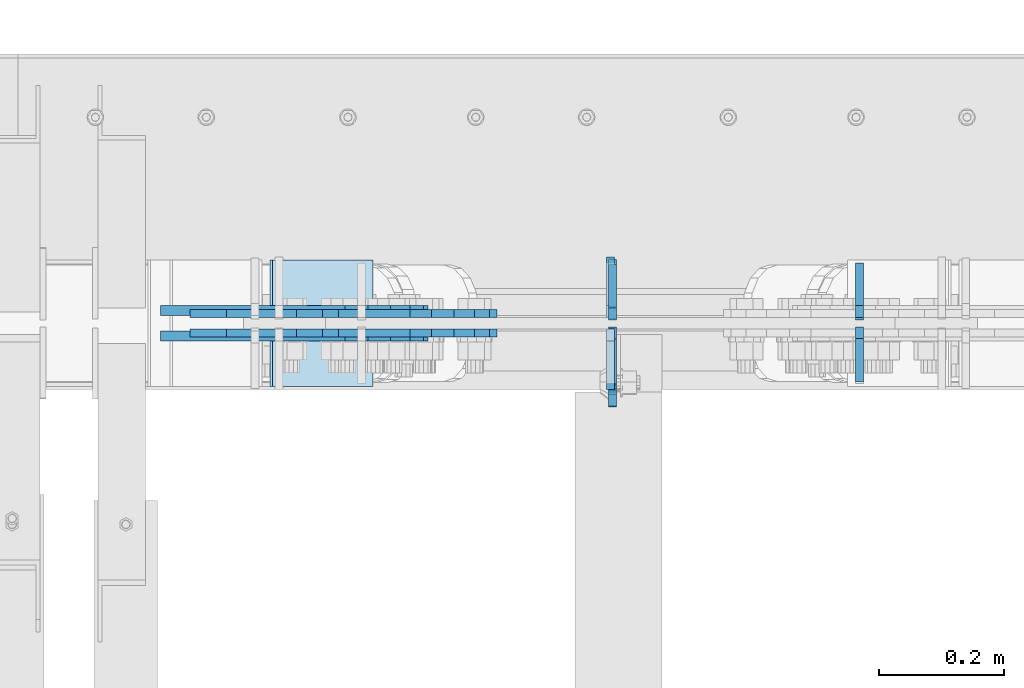
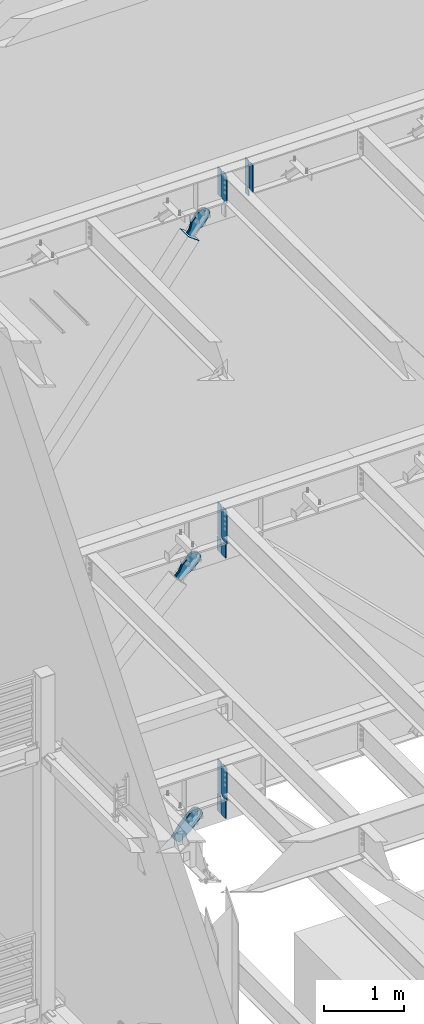
# One storey, part 1069 of 1179: 20 plates, 10 elements without a shape of their own.
"""IFC2X3 building model written with IfcOpenShell, lengths in millimetres."""

from ifc_helpers import new_model, si_unit, frame, origin_with_axes, place, context, subcontext, project, spatial, faceted_brep, material, type_object, element, aggregate, save


model = new_model("IFC2X3")

# Units and contexts
model_context = context("Model", 3, precision=1e-05, world=origin_with_axes())
body_context = subcontext(model_context, "Body", "Model", "MODEL_VIEW")
ifc_project = project(units=[si_unit("LENGTHUNIT", "METRE", prefix="MILLI"), si_unit("AREAUNIT", "SQUARE_METRE"), si_unit("VOLUMEUNIT", "CUBIC_METRE"), si_unit("MASSUNIT", "GRAM", prefix="KILO"), si_unit("TIMEUNIT", "SECOND"), si_unit("PLANEANGLEUNIT", "RADIAN"), si_unit("SOLIDANGLEUNIT", "STERADIAN"), si_unit("THERMODYNAMICTEMPERATUREUNIT", "DEGREE_CELSIUS"), si_unit("LUMINOUSINTENSITYUNIT", "LUMEN")], contexts=[model_context])

# Site, building, storey
site_placement = place(None, origin_with_axes())
site = spatial("IfcSite", under=ifc_project, at=site_placement, CompositionType="ELEMENT")
building_placement = place(site_placement, origin_with_axes())
building = spatial("IfcBuilding", under=site, at=building_placement, Name="Undefined", CompositionType="ELEMENT")
storey_placement = place(building_placement, origin_with_axes())
storey = spatial("IfcBuildingStorey", under=building, at=storey_placement, Name="Undefined", CompositionType="ELEMENT", Elevation=0.0)

# Assembly, plate
assembly_1_placement = place(storey_placement, origin_with_axes())
assembly_1 = element("IfcElementAssembly", 1, at=assembly_1_placement, inside=storey, Name="BEAM", AssemblyPlace="NOTDEFINED", PredefinedType="RIGID_FRAME")
ifc_material_1 = material(Name="STEEL/A572-GR.50")
plate_type_1 = type_object("IfcPlateType", PredefinedType="NOTDEFINED")
plate_1_placement = place(assembly_1_placement, frame((4359.27488286661, 41205.94375, 7489.825), z_axis=(0.0, 0.0, 1.0), x_axis=(0.0, 1.0, 0.0)))
plate_1 = element("IfcPlate", 2, at=plate_1_placement, type_object=plate_type_1, material=ifc_material_1, Name="PLATE", context=body_context, shape_type="Brep", body=[
    faceted_brep([(0.0, -6.35000000000036, 19.0499999999993), (0.0, -6.350000000195, 479.425000761541), (0.0, 6.34999999980209, 479.425000761548), (0.0, 6.35000000000036, 19.0499999999993), (19.0499992370605, -6.35000000019863, 498.474999998592), (19.0499992370605, 6.34999999979118, 498.474999998596), (95.25, -6.349999999793, 498.474999998598), (95.25, 6.35000000020045, 498.474999998592), (95.25, -6.34999999999309, 1.81898940354586e-12), (95.25, 6.34999999999854, -1.81898940354586e-12), (19.0500000000002, -6.35000000000036, 0.0), (19.0500000000002, 6.35000000000036, 0.0)], [[[0, 1, 2, 3]], [[1, 4, 5, 2]], [[4, 6, 7, 5]], [[6, 8, 9, 7]], [[8, 10, 11, 9]], [[3, 11, 10, 0]], [[5, 7, 9, 11, 3, 2]], [[10, 8, 6, 4, 1, 0]]]),
])

assembly_2_placement = place(storey_placement, origin_with_axes())
assembly_2 = element("IfcElementAssembly", 3, at=assembly_2_placement, inside=storey, Name="BEAM", AssemblyPlace="NOTDEFINED", PredefinedType="RIGID_FRAME")
plate_2_placement = place(assembly_2_placement, frame((4359.27477863734, 41205.94375, 3578.225), z_axis=(0.0, 0.0, 1.0), x_axis=(0.0, 1.0, 0.0)))
plate_2 = element("IfcPlate", 4, at=plate_2_placement, type_object=plate_type_1, material=ifc_material_1, Name="PLATE", context=body_context, shape_type="Brep", body=[
    faceted_brep([(0.0, -6.35000000000036, 19.0499999999993), (0.0, -6.350000000195, 479.425000761541), (0.0, 6.34999999980209, 479.425000761548), (0.0, 6.35000000000036, 19.0499999999993), (19.0499992370605, -6.35000000019863, 498.474999998592), (19.0499992370605, 6.34999999979118, 498.474999998596), (95.25, -6.349999999793, 498.474999998598), (95.25, 6.35000000020045, 498.474999998592), (95.25, -6.34999999999309, 1.81898940354586e-12), (95.25, 6.34999999999854, -1.81898940354586e-12), (19.0500000000002, -6.35000000000036, 0.0), (19.0500000000002, 6.35000000000036, 0.0)], [[[0, 1, 2, 3]], [[1, 4, 5, 2]], [[4, 6, 7, 5]], [[6, 8, 9, 7]], [[8, 10, 11, 9]], [[3, 11, 10, 0]], [[5, 7, 9, 11, 3, 2]], [[10, 8, 6, 4, 1, 0]]]),
])

assembly_3_placement = place(storey_placement, origin_with_axes())
assembly_3 = element("IfcElementAssembly", 5, at=assembly_3_placement, inside=storey, Name="Plate", AssemblyPlace="NOTDEFINED", PredefinedType="RIGID_FRAME")
ifc_material_2 = material(Name="STEEL/A36")
plate_type_2 = type_object("IfcPlateType", PredefinedType="NOTDEFINED")
plate_3_placement = place(assembly_3_placement, frame((3974.02897240542, 41097.2, 12217.0925888361), z_axis=(-0.795206441873757, 0.0, 0.606338778903741), x_axis=(0.0, 1.0, 0.0)))
plate_3 = element("IfcPlate", 6, at=plate_3_placement, type_object=plate_type_2, material=ifc_material_2, Name="Plate", context=body_context, shape_type="Brep", body=[
    faceted_brep([(0.0, -3.17500000000109, 0.0), (0.0, -3.17500000000291, 203.200000000368), (0.0, 3.17499999998836, 203.200000000361), (0.0, 3.17500000000109, 7.27595761418343e-12), (203.199999999997, -3.17500000000291, 203.200000000368), (203.199999999997, 3.17499999998836, 203.200000000361), (203.199999999997, -3.17499999999927, 3.63797880709171e-12), (203.199999999997, 3.17499999999382, -3.63797880709171e-12)], [[[0, 1, 2, 3]], [[1, 4, 5, 2]], [[4, 6, 7, 5]], [[6, 0, 3, 7]], [[5, 7, 3, 2]], [[6, 4, 1, 0]]]),
])
aggregate(assembly_3, [plate_3])

assembly_4_placement = place(storey_placement, origin_with_axes())
assembly_4 = element("IfcElementAssembly", 7, at=assembly_4_placement, inside=storey, Name="BEAM", AssemblyPlace="NOTDEFINED", PredefinedType="RIGID_FRAME")
plate_type_3 = type_object("IfcPlateType", PredefinedType="NOTDEFINED")
plate_4_placement = place(assembly_4_placement, frame((4755.23166249237, 41208.325, 12652.3749993443), z_axis=(0.0, 1.0, 0.0), x_axis=(0.0, 0.0, -1.0)))
plate_4 = element("IfcPlate", 8, at=plate_4_placement, type_object=plate_type_3, material=ifc_material_1, Name="PLATE", context=body_context, shape_type="Brep", body=[
    faceted_brep([(0.0, 6.35000000000036, 19.0499999999993), (19.0500000000002, 6.35000000000036, 0.0), (19.0500000000002, -6.35000000000036, 0.0), (0.0, -6.35000000000036, 19.0499999999993), (0.0, -6.35000000000036, 87.3125), (0.0, 6.35000000000036, 87.3125), (92.4827269854632, -6.35000000000036, 87.3125), (92.4827269854632, 6.35000000000036, 87.3125), (92.4827269854632, -6.35000000000036, 0.0), (92.4827269854632, 6.35000000000036, 0.0)], [[[0, 1, 2, 3]], [[4, 5, 0, 3]], [[4, 6, 7, 5]], [[6, 8, 9, 7]], [[9, 8, 2, 1]], [[5, 7, 9, 1, 0]], [[8, 6, 4, 3, 2]]]),
])

# Plate
plate_type_4 = type_object("IfcPlateType", PredefinedType="NOTDEFINED")
plate_5_placement = place(assembly_1_placement, frame((4356.09999912136, 41208.325, 7464.425), z_axis=(0.0, 1.0, 0.0), x_axis=(0.0, 0.0, -1.0)))
plate_5 = element("IfcPlate", 9, at=plate_5_placement, type_object=plate_type_4, material=ifc_material_1, Name="PLATE", context=body_context, shape_type="Brep", body=[
    faceted_brep([(0.0, 6.35000000000036, 19.0499999999993), (19.0500000000002, 6.35000000000036, 0.0), (19.0500000000002, -6.35000000000036, 0.0), (0.0, -6.35000000000036, 19.0499999999993), (0.0, -6.35000000000036, 96.8374999999978), (0.0, 6.35000000000036, 96.8374999999978), (210.586547343888, -6.35000000000036, 96.8375000000015), (210.586547343888, 6.35000000000036, 96.8375000000015), (210.586547343888, -6.35000000000036, 0.0), (210.586547343888, 6.35000000000036, 0.0)], [[[0, 1, 2, 3]], [[4, 5, 0, 3]], [[4, 6, 7, 5]], [[6, 8, 9, 7]], [[9, 8, 2, 1]], [[5, 7, 9, 1, 0]], [[8, 6, 4, 3, 2]]]),
])

plate_6_placement = place(assembly_1_placement, frame((4356.09999912136, 41189.275, 7464.425), z_axis=(0.0, -1.0, 0.0), x_axis=(0.0, 0.0, -1.0)))
plate_6 = element("IfcPlate", 10, at=plate_6_placement, type_object=plate_type_4, material=ifc_material_1, Name="PLATE", context=body_context, shape_type="Brep", body=[
    faceted_brep([(0.0, 6.35000000000036, 19.0499999999993), (19.0500000000002, 6.35000000000036, 0.0), (19.0500000000002, -6.35000000000036, 0.0), (0.0, -6.35000000000036, 19.0499999999993), (0.0, -6.35000000000036, 96.8374999999978), (0.0, 6.35000000000036, 96.8374999999978), (210.586547343888, -6.35000000000036, 96.8375000000015), (210.586547343888, 6.35000000000036, 96.8375000000015), (210.586547343888, -6.35000000000036, 0.0), (210.586547343888, 6.35000000000036, 0.0)], [[[0, 1, 2, 3]], [[4, 5, 0, 3]], [[4, 6, 7, 5]], [[6, 8, 9, 7]], [[9, 8, 2, 1]], [[5, 7, 9, 1, 0]], [[8, 6, 4, 3, 2]]]),
])

plate_type_5 = type_object("IfcPlateType", PredefinedType="NOTDEFINED")
plate_7_placement = place(assembly_4_placement, frame((4755.25703537455, 41104.34375, 12673.0125), z_axis=(0.0, 0.0, 1.0), x_axis=(0.0, 1.0, 0.0)))
plate_7 = element("IfcPlate", 11, at=plate_7_placement, type_object=plate_type_5, material=ifc_material_1, Name="PLATE", context=body_context, shape_type="Brep", body=[
    faceted_brep([(0.0, -6.34999999999854, 0.0), (0.0, -6.34999999999991, 425.450012207031), (0.0, 6.34999999999991, 425.450012207031), (0.0, 6.34999999999854, 0.0), (69.8500022888184, -6.34999999999991, 425.450012207031), (69.8500022888184, 6.34999999999991, 425.450012207031), (88.9000015258789, -6.34999999999991, 406.400012969971), (88.9000015258789, 6.34999999999991, 406.400012969971), (88.9000015258789, -6.34999999999991, 19.0499992370605), (88.9000015258789, 6.34999999999991, 19.0499992370605), (69.849999425729, -6.34999999999854, 0.0), (69.849999425729, 6.34999999999854, 0.0)], [[[0, 1, 2, 3]], [[1, 4, 5, 2]], [[4, 6, 7, 5]], [[6, 8, 9, 7]], [[8, 10, 11, 9]], [[10, 0, 3, 11]], [[5, 7, 9, 11, 3, 2]], [[10, 8, 6, 4, 1, 0]]]),
])

plate_8_placement = place(assembly_4_placement, frame((4755.25703537455, 41204.35625, 12673.0125), z_axis=(0.0, 0.0, 1.0), x_axis=(0.0, 1.0, 0.0)))
plate_8 = element("IfcPlate", 12, at=plate_8_placement, type_object=plate_type_5, material=ifc_material_1, Name="PLATE", context=body_context, shape_type="Brep", body=[
    faceted_brep([(0.0, -6.35000000000036, 19.0499999999993), (0.0, -6.34999999999991, 406.400012969971), (0.0, 6.34999999999991, 406.400012969971), (0.0, 6.35000000000036, 19.0499999999993), (19.0499992370605, -6.34999999999991, 425.450012207031), (19.0499992370605, 6.34999999999991, 425.450012207031), (88.9000015258789, -6.34999999999991, 425.450012207031), (88.9000015258789, 6.34999999999991, 425.450012207031), (88.9000015258789, -6.34999999999991, 0.0), (88.9000015258789, 6.34999999999991, 0.0), (19.0500000000002, -6.35000000000036, 0.0), (19.0500000000002, 6.35000000000036, 0.0)], [[[0, 1, 2, 3]], [[1, 4, 5, 2]], [[4, 6, 7, 5]], [[6, 8, 9, 7]], [[8, 10, 11, 9]], [[3, 11, 10, 0]], [[5, 7, 9, 11, 3, 2]], [[10, 8, 6, 4, 1, 0]]]),
])

plate_9_placement = place(assembly_4_placement, frame((4359.275, 41204.35625, 12673.0125), z_axis=(0.0, 0.0, 1.0), x_axis=(0.0, 1.0, 0.0)))
plate_9 = element("IfcPlate", 13, at=plate_9_placement, type_object=plate_type_5, material=ifc_material_1, Name="PLATE", context=body_context, shape_type="Brep", body=[
    faceted_brep([(0.0, -6.35000000000036, 19.0499999999993), (0.0, -6.34999999999991, 406.400012969971), (0.0, 6.34999999999991, 406.400012969971), (0.0, 6.35000000000036, 19.0499999999993), (19.0499992370605, -6.34999999999991, 425.450012207031), (19.0499992370605, 6.34999999999991, 425.450012207031), (88.9000015258789, -6.34999999999991, 425.450012207031), (88.9000015258789, 6.34999999999991, 425.450012207031), (88.9000015258789, -6.34999999999991, 0.0), (88.9000015258789, 6.34999999999991, 0.0), (19.0500000000002, -6.35000000000036, 0.0), (19.0500000000002, 6.35000000000036, 0.0)], [[[0, 1, 2, 3]], [[1, 4, 5, 2]], [[4, 6, 7, 5]], [[6, 8, 9, 7]], [[8, 10, 11, 9]], [[3, 11, 10, 0]], [[5, 7, 9, 11, 3, 2]], [[10, 8, 6, 4, 1, 0]]]),
])

plate_type_6 = type_object("IfcPlateType", PredefinedType="NOTDEFINED")
plate_10_placement = place(assembly_4_placement, frame((4359.275, 41193.24375, 12673.0125), z_axis=(0.0, 0.0, 1.0), x_axis=(0.0, -1.0, 0.0)))
plate_10 = element("IfcPlate", 14, at=plate_10_placement, type_object=plate_type_6, material=ifc_material_1, Name="PLATE", context=body_context, shape_type="Brep", body=[
    faceted_brep([(91.2812527563583, -6.35000000000036, 425.450000000001), (91.2812527563583, -6.35000000000036, 420.68750041225), (91.2812527563583, 6.35000000000036, 420.68750041225), (91.2812527563583, 6.35000000000036, 425.450000000001), (92.2479826789495, -6.35000000000036, 415.827420894204), (92.2479826789495, 6.35000000000036, 415.827420894204), (95.0009965794234, -6.35000000000036, 411.70724442605), (95.0009965794234, 6.35000000000036, 411.70724442605), (99.121173047577, -6.35000000000036, 408.954230525573), (99.121173047577, 6.35000000000036, 408.954230525573), (103.981252565623, -6.35000000000036, 407.987500602985), (103.981252565623, 6.35000000000036, 407.987500602985), (127.000010385753, -6.35000000000036, 407.987500602985), (127.000004873051, 6.35000000000036, 407.987500602985), (0.0, -6.34999999999991, 406.400012969971), (19.0499992370605, -6.34999999999991, 425.450012207031), (19.0499992370605, 6.34999999999991, 425.450012207031), (0.0, 6.34999999999991, 406.400012969971), (0.0, -6.35000000000036, 19.0499999999993), (0.0, 6.35000000000036, 19.0499999999993), (19.0500000000002, 6.35000000000036, 0.0), (19.0500000000002, -6.35000000000036, 0.0), (127.000004873051, -6.34999999999854, 0.0), (127.000004873051, 6.34999999999854, 0.0)], [[[0, 1, 2, 3]], [[4, 5, 2, 1]], [[6, 7, 5, 4]], [[8, 9, 7, 6]], [[10, 11, 9, 8]], [[12, 13, 11, 10]], [[14, 15, 16, 17]], [[18, 14, 17, 19]], [[19, 20, 21, 18]], [[22, 21, 20, 23]], [[8, 6, 4, 1, 0, 15, 14, 18, 21, 22, 12, 10]], [[16, 15, 0, 3]], [[23, 20, 19, 17, 16, 3, 2, 5, 7, 9, 11, 13]], [[22, 23, 13, 12]]]),
])

aggregate(assembly_4, [plate_7, plate_8, plate_4, plate_9, plate_10])

plate_11_placement = place(assembly_1_placement, frame((4359.27488286661, 41191.65625, 7489.825), z_axis=(0.0, 0.0, 1.0), x_axis=(0.0, -1.0, 0.0)))
plate_11 = element("IfcPlate", 15, at=plate_11_placement, type_object=plate_type_6, material=ifc_material_1, Name="PLATE", context=body_context, shape_type="Brep", body=[
    faceted_brep([(99.21875, -6.35000000020227, 498.474999998592), (99.2187500000146, -6.35000000000036, 492.124999809268), (99.2187500000146, 6.35000000000036, 492.124999809268), (99.21875, 6.34999999978754, 498.474999998596), (100.185479922602, -6.35000000000036, 487.264920291223), (100.185479922602, 6.35000000000036, 487.264920291223), (102.93849382308, -6.35000000000036, 483.144743823069), (102.93849382308, 6.35000000000036, 483.144743823069), (107.058670291233, -6.35000000000036, 480.39172992259), (107.058670291233, 6.35000000000036, 480.39172992259), (111.91874980928, -6.35000000000036, 479.425000000003), (111.91874980928, 6.35000000000036, 479.425000000003), (127.000007629409, -6.35000000000036, 479.425000000003), (127.000004683807, 6.35000000000036, 479.425000000003), (0.0, -6.350000000195, 479.425000761541), (19.0499992370605, -6.35000000019863, 498.474999998592), (19.0499992370605, 6.34999999979118, 498.474999998596), (0.0, 6.34999999980209, 479.425000761548), (0.0, -6.35000000000036, 19.0499999999993), (0.0, 6.35000000000036, 19.0499999999993), (19.0500000000002, 6.35000000000036, 0.0), (19.0500000000002, -6.35000000000036, 0.0), (127.000004873051, -6.34999999999854, 0.0), (127.000004873051, 6.34999999999854, 0.0)], [[[0, 1, 2, 3]], [[4, 5, 2, 1]], [[6, 7, 5, 4]], [[8, 9, 7, 6]], [[10, 11, 9, 8]], [[12, 13, 11, 10]], [[14, 15, 16, 17]], [[18, 14, 17, 19]], [[19, 20, 21, 18]], [[22, 21, 20, 23]], [[8, 6, 4, 1, 0, 15, 14, 18, 21, 22, 12, 10]], [[15, 0, 3, 16]], [[23, 20, 19, 17, 16, 3, 2, 5, 7, 9, 11, 13]], [[22, 23, 13, 12]]]),
])

aggregate(assembly_1, [plate_5, plate_6, plate_1, plate_11])

plate_12_placement = place(assembly_2_placement, frame((4359.27477865803, 41191.6562498413, 3578.225), z_axis=(0.0, 0.0, 1.0), x_axis=(0.0, -1.0, 0.0)))
plate_12 = element("IfcPlate", 16, at=plate_12_placement, type_object=plate_type_6, material=ifc_material_1, Name="PLATE", context=body_context, shape_type="Brep", body=[
    faceted_brep([(100.185729598081, -6.34999999998126, 493.614920291231), (100.185729712379, 6.35000000001855, 493.614920291231), (99.2189997897876, 6.35000000001764, 498.475), (99.2189996754969, -6.34999999998217, 498.475), (102.938743498562, -6.34999999998035, 489.494743823076), (102.93874361286, 6.35000000001946, 489.494743823076), (107.058919966723, -6.34999999998035, 486.741729922599), (107.058920081021, 6.35000000001946, 486.741729922599), (111.918999484777, -6.34999999997945, 485.775000000015), (111.918999599067, 6.35000000002037, 485.775000000015), (127.000007633353, -6.34999999997581, 485.775000000033), (127.000004873036, 6.35000000002401, 485.775000000033), (0.0, -6.350000000195, 479.425000761541), (19.0499992370605, -6.35000000019863, 498.474999998592), (19.0499992370605, 6.34999999979118, 498.474999998596), (0.0, 6.34999999980209, 479.425000761548), (0.0, -6.35000000000036, 19.0499999999993), (0.0, 6.35000000000036, 19.0499999999993), (19.0500000000002, 6.35000000000036, 0.0), (19.0500000000002, -6.35000000000036, 0.0), (127.000004873051, -6.34999999999854, 0.0), (127.000004873051, 6.34999999999854, 0.0)], [[[0, 1, 2, 3]], [[4, 5, 1, 0]], [[6, 7, 5, 4]], [[8, 9, 7, 6]], [[10, 11, 9, 8]], [[12, 13, 14, 15]], [[16, 12, 15, 17]], [[17, 18, 19, 16]], [[20, 19, 18, 21]], [[6, 4, 0, 3, 13, 12, 16, 19, 20, 10, 8]], [[14, 13, 3, 2]], [[21, 18, 17, 15, 14, 2, 1, 5, 7, 9, 11]], [[20, 21, 11, 10]]]),
])

plate_type_7 = type_object("IfcPlateType", PredefinedType="NOTDEFINED")
plate_13_placement = place(assembly_2_placement, frame((4356.09999808618, 41211.5, 3552.825), z_axis=(0.0, 1.0, 0.0), x_axis=(0.0, 0.0, -1.0)))
plate_13 = element("IfcPlate", 17, at=plate_13_placement, type_object=plate_type_7, material=ifc_material_1, Name="PLATE", context=body_context, shape_type="Brep", body=[
    faceted_brep([(0.0, -6.35000000000036, 93.6625000000058), (0.0, 6.35000000000036, 93.6625000000058), (0.0, 6.35000000000036, 19.0499999999993), (0.0, -6.35000000000036, 19.0499999999993), (264.218438426346, -6.35000000000036, 93.6625000000058), (264.218438426346, 6.35000000000036, 93.6625000000058), (264.218438426346, -6.35000000000036, 0.0), (264.218438426346, 6.35000000000036, 0.0), (19.0500000000002, -6.35000000000036, 0.0), (19.0500000000002, 6.35000000000036, 0.0)], [[[0, 1, 2, 3]], [[0, 4, 5, 1]], [[4, 6, 7, 5]], [[6, 8, 9, 7]], [[2, 9, 8, 3]], [[5, 7, 9, 2, 1]], [[8, 6, 4, 0, 3]]]),
])

plate_14_placement = place(assembly_2_placement, frame((4356.09999808618, 41186.1, 3552.825), z_axis=(0.0, -1.0, 0.0), x_axis=(0.0, 0.0, -1.0)))
plate_14 = element("IfcPlate", 18, at=plate_14_placement, type_object=plate_type_7, material=ifc_material_1, Name="PLATE", context=body_context, shape_type="Brep", body=[
    faceted_brep([(0.0, -6.35000000000036, 93.6625000000058), (0.0, 6.35000000000036, 93.6625000000058), (0.0, 6.35000000000036, 19.0499999999993), (0.0, -6.35000000000036, 19.0499999999993), (264.218438426346, -6.35000000000036, 93.6625000000058), (264.218438426346, 6.35000000000036, 93.6625000000058), (264.218438426346, -6.35000000000036, 0.0), (264.218438426346, 6.35000000000036, 0.0), (19.0500000000002, -6.35000000000036, 0.0), (19.0500000000002, 6.35000000000036, 0.0)], [[[0, 1, 2, 3]], [[0, 4, 5, 1]], [[4, 6, 7, 5]], [[6, 8, 9, 7]], [[2, 9, 8, 3]], [[5, 7, 9, 2, 1]], [[8, 6, 4, 0, 3]]]),
])

aggregate(assembly_2, [plate_13, plate_14, plate_2, plate_12])

# Assembly, plate
assembly_5_placement = place(storey_placement, origin_with_axes())
assembly_5 = element("IfcElementAssembly", 19, at=assembly_5_placement, inside=storey, AssemblyPlace="NOTDEFINED", PredefinedType="RIGID_FRAME")
plate_type_8 = type_object("IfcPlateType", PredefinedType="NOTDEFINED")
plate_15_placement = place(assembly_5_placement, frame((3929.93946276912, 41214.675, 12246.717826004), z_axis=(-0.795206441873757, 0.0, 0.606338778903741), x_axis=(0.606338778903741, 0.0, 0.795206441873757)))
plate_15 = element("IfcPlate", 20, at=plate_15_placement, type_object=plate_type_8, material=ifc_material_2, context=body_context, shape_type="Brep", body=[
    faceted_brep([(0.0, -6.34999999999854, 0.0), (4.938556230627e-10, -6.34999999999854, 97.1536165479993), (4.938556230627e-10, 6.34999999999854, 97.1536165479993), (0.0, 6.34999999999854, 0.0), (68.5800000003655, -6.34999999999854, 97.153616547841), (68.5800000003655, 6.34999999999854, 97.153616547841), (170.180000000595, -6.34999999999854, 142.239308273867), (170.180000000595, 6.34999999999854, 142.239308273867), (313.949242323917, -6.34999999999854, 142.239308273847), (313.949242323917, 6.34999999999854, 142.239308273847), (349.792328723946, -6.34999999999854, 135.109675103793), (349.792328723946, 6.34999999999854, 135.109675103793), (380.178630137938, -6.34999999999854, 114.80619761351), (380.178630137938, 6.34999999999854, 114.80619761351), (400.482107628101, -6.34999999999854, 84.4198961994261), (400.482107628101, 6.34999999999854, 84.4198961994261), (407.611740798023, -6.34999999999854, 48.5768067476838), (407.611740798023, 6.34999999999854, 48.5768067476838), (400.482107627932, -6.34999999999854, 12.7337203478164), (400.482107627932, 6.34999999999854, 12.7337203478164), (380.178630137746, -6.34999999999854, -17.6525810660296), (380.178630137746, 6.34999999999854, -17.6525810660296), (349.79232872385, -6.34999999999854, -37.9560585561248), (349.79232872385, 6.34999999999854, -37.9560585561248), (313.949240797645, -6.34999999999854, -45.085691726099), (313.949240797645, 6.34999999999854, -45.085691726099), (170.17999999998, -6.34999999999854, -45.0856917260735), (170.17999999998, 6.34999999999854, -45.0856917260735), (68.5800000000518, -6.34999999999854, -9.09494701772928e-12), (68.5800000000518, 6.34999999999854, -9.09494701772928e-12)], [[[0, 1, 2, 3]], [[1, 4, 5, 2]], [[4, 6, 7, 5]], [[6, 8, 9, 7]], [[8, 10, 11, 9]], [[10, 12, 13, 11]], [[12, 14, 15, 13]], [[14, 16, 17, 15]], [[16, 18, 19, 17]], [[18, 20, 21, 19]], [[20, 22, 23, 21]], [[22, 24, 25, 23]], [[24, 26, 27, 25]], [[26, 28, 29, 27]], [[28, 0, 3, 29]], [[5, 7, 9, 11, 13, 15, 17, 19, 21, 23, 25, 27, 29, 3, 2]], [[28, 26, 24, 22, 20, 18, 16, 14, 12, 10, 8, 6, 4, 1, 0]]]),
])
aggregate(assembly_5, [plate_15])

assembly_6_placement = place(storey_placement, origin_with_axes())
assembly_6 = element("IfcElementAssembly", 21, at=assembly_6_placement, inside=storey, AssemblyPlace="NOTDEFINED", PredefinedType="RIGID_FRAME")
plate_16_placement = place(assembly_6_placement, frame((3929.93946276912, 41182.925, 12246.717826004), z_axis=(-0.795206441873757, 0.0, 0.606338778903741), x_axis=(0.606338778903741, 0.0, 0.795206441873757)))
plate_16 = element("IfcPlate", 22, at=plate_16_placement, type_object=plate_type_8, material=ifc_material_2, context=body_context, shape_type="Brep", body=[
    faceted_brep([(0.0, -6.34999999999854, 0.0), (4.938556230627e-10, -6.34999999999854, 97.1536165479993), (4.938556230627e-10, 6.34999999999854, 97.1536165479993), (0.0, 6.34999999999854, 0.0), (68.5800000003655, -6.34999999999854, 97.153616547841), (68.5800000003655, 6.34999999999854, 97.153616547841), (170.180000000595, -6.34999999999854, 142.239308273867), (170.180000000595, 6.34999999999854, 142.239308273867), (313.949242323917, -6.34999999999854, 142.239308273847), (313.949242323917, 6.34999999999854, 142.239308273847), (349.792328723946, -6.34999999999854, 135.109675103793), (349.792328723946, 6.34999999999854, 135.109675103793), (380.178630137938, -6.34999999999854, 114.80619761351), (380.178630137938, 6.34999999999854, 114.80619761351), (400.482107628101, -6.34999999999854, 84.4198961994261), (400.482107628101, 6.34999999999854, 84.4198961994261), (407.611740798023, -6.34999999999854, 48.5768067476838), (407.611740798023, 6.34999999999854, 48.5768067476838), (400.482107627932, -6.34999999999854, 12.7337203478164), (400.482107627932, 6.34999999999854, 12.7337203478164), (380.178630137746, -6.34999999999854, -17.6525810660296), (380.178630137746, 6.34999999999854, -17.6525810660296), (349.79232872385, -6.34999999999854, -37.9560585561248), (349.79232872385, 6.34999999999854, -37.9560585561248), (313.949240797645, -6.34999999999854, -45.085691726099), (313.949240797645, 6.34999999999854, -45.085691726099), (170.17999999998, -6.34999999999854, -45.0856917260735), (170.17999999998, 6.34999999999854, -45.0856917260735), (68.5800000000518, -6.34999999999854, -9.09494701772928e-12), (68.5800000000518, 6.34999999999854, -9.09494701772928e-12)], [[[0, 1, 2, 3]], [[1, 4, 5, 2]], [[4, 6, 7, 5]], [[6, 8, 9, 7]], [[8, 10, 11, 9]], [[10, 12, 13, 11]], [[12, 14, 15, 13]], [[14, 16, 17, 15]], [[16, 18, 19, 17]], [[18, 20, 21, 19]], [[20, 22, 23, 21]], [[22, 24, 25, 23]], [[24, 26, 27, 25]], [[26, 28, 29, 27]], [[28, 0, 3, 29]], [[5, 7, 9, 11, 13, 15, 17, 19, 21, 23, 25, 27, 29, 3, 2]], [[28, 26, 24, 22, 20, 18, 16, 14, 12, 10, 8, 6, 4, 1, 0]]]),
])
aggregate(assembly_6, [plate_16])

assembly_7_placement = place(storey_placement, origin_with_axes())
assembly_7 = element("IfcElementAssembly", 23, at=assembly_7_placement, inside=storey, AssemblyPlace="NOTDEFINED", PredefinedType="RIGID_FRAME")
plate_17_placement = place(assembly_7_placement, frame((3761.14514710402, 41214.675, 7066.8345998703), z_axis=(-0.705959813968941, 0.0, 0.708251890968841), x_axis=(0.70825189096884, 0.0, 0.705959813968941)))
plate_17 = element("IfcPlate", 24, at=plate_17_placement, type_object=plate_type_8, material=ifc_material_2, context=body_context, shape_type="Brep", body=[
    faceted_brep([(0.0, -6.34999999999854, 0.0), (-4.35647962149233e-10, -6.34999999999854, 112.184930806416), (-4.35647962149233e-10, 6.34999999999854, 112.184930806416), (0.0, 6.34999999999854, 0.0), (82.5499999996491, -6.34999999999854, 112.184930806461), (82.5499999996491, 6.34999999999854, 112.184930806461), (184.149999999618, -6.34999999999854, 149.75496540347), (184.149999999618, 6.34999999999854, 149.75496540347), (327.919242323534, -6.34999999999854, 149.754965403559), (327.919242323534, 6.34999999999854, 149.754965403559), (363.762328723451, -6.34999999999854, 142.625332233587), (363.762328723451, 6.34999999999854, 142.625332233587), (394.148630137406, -6.34999999999854, 122.321854743475), (394.148630137406, 6.34999999999854, 122.321854743475), (414.452107627645, -6.34999999999854, 91.9355533295929), (414.452107627645, 6.34999999999854, 91.9355533295929), (421.581740797776, -6.34999999999854, 56.0924638777396), (421.581740797776, 6.34999999999854, 56.0924638777396), (414.452107627878, -6.34999999999854, 20.2493774776722), (414.452107627878, 6.34999999999854, 20.2493774776722), (394.14863013775, -6.34999999999854, -10.1369239363994), (394.14863013775, 6.34999999999854, -10.1369239363994), (363.762328723789, -6.34999999999854, -30.4404014266784), (363.762328723789, 6.34999999999854, -30.4404014266784), (327.919240798041, -6.34999999999854, -37.570034596738), (327.919240798041, 6.34999999999854, -37.570034596738), (184.150000000338, -6.34999999999854, -37.5700345968289), (184.150000000338, 6.34999999999854, -37.5700345968289), (82.550000000203, -6.34999999999854, 1.2732925824821e-10), (82.550000000203, 6.34999999999854, 1.2732925824821e-10)], [[[0, 1, 2, 3]], [[1, 4, 5, 2]], [[4, 6, 7, 5]], [[6, 8, 9, 7]], [[8, 10, 11, 9]], [[10, 12, 13, 11]], [[12, 14, 15, 13]], [[14, 16, 17, 15]], [[16, 18, 19, 17]], [[18, 20, 21, 19]], [[20, 22, 23, 21]], [[22, 24, 25, 23]], [[24, 26, 27, 25]], [[26, 28, 29, 27]], [[28, 0, 3, 29]], [[5, 7, 9, 11, 13, 15, 17, 19, 21, 23, 25, 27, 29, 3, 2]], [[28, 26, 24, 22, 20, 18, 16, 14, 12, 10, 8, 6, 4, 1, 0]]]),
])
aggregate(assembly_7, [plate_17])

assembly_8_placement = place(storey_placement, origin_with_axes())
assembly_8 = element("IfcElementAssembly", 25, at=assembly_8_placement, inside=storey, AssemblyPlace="NOTDEFINED", PredefinedType="RIGID_FRAME")
plate_18_placement = place(assembly_8_placement, frame((3761.14514710402, 41182.925, 7066.8345998703), z_axis=(-0.705959813968941, 0.0, 0.708251890968841), x_axis=(0.70825189096884, 0.0, 0.705959813968941)))
plate_18 = element("IfcPlate", 26, at=plate_18_placement, type_object=plate_type_8, material=ifc_material_2, context=body_context, shape_type="Brep", body=[
    faceted_brep([(0.0, -6.34999999999854, 0.0), (-4.35647962149233e-10, -6.34999999999854, 112.184930806416), (-4.35647962149233e-10, 6.34999999999854, 112.184930806416), (0.0, 6.34999999999854, 0.0), (82.5499999996491, -6.34999999999854, 112.184930806461), (82.5499999996491, 6.34999999999854, 112.184930806461), (184.149999999618, -6.34999999999854, 149.75496540347), (184.149999999618, 6.34999999999854, 149.75496540347), (327.919242323534, -6.34999999999854, 149.754965403559), (327.919242323534, 6.34999999999854, 149.754965403559), (363.762328723451, -6.34999999999854, 142.625332233587), (363.762328723451, 6.34999999999854, 142.625332233587), (394.148630137406, -6.34999999999854, 122.321854743475), (394.148630137406, 6.34999999999854, 122.321854743475), (414.452107627645, -6.34999999999854, 91.9355533295929), (414.452107627645, 6.34999999999854, 91.9355533295929), (421.581740797776, -6.34999999999854, 56.0924638777396), (421.581740797776, 6.34999999999854, 56.0924638777396), (414.452107627878, -6.34999999999854, 20.2493774776722), (414.452107627878, 6.34999999999854, 20.2493774776722), (394.14863013775, -6.34999999999854, -10.1369239363994), (394.14863013775, 6.34999999999854, -10.1369239363994), (363.762328723789, -6.34999999999854, -30.4404014266784), (363.762328723789, 6.34999999999854, -30.4404014266784), (327.919240798041, -6.34999999999854, -37.570034596738), (327.919240798041, 6.34999999999854, -37.570034596738), (184.150000000338, -6.34999999999854, -37.5700345968289), (184.150000000338, 6.34999999999854, -37.5700345968289), (82.550000000203, -6.34999999999854, 1.2732925824821e-10), (82.550000000203, 6.34999999999854, 1.2732925824821e-10)], [[[0, 1, 2, 3]], [[1, 4, 5, 2]], [[4, 6, 7, 5]], [[6, 8, 9, 7]], [[8, 10, 11, 9]], [[10, 12, 13, 11]], [[12, 14, 15, 13]], [[14, 16, 17, 15]], [[16, 18, 19, 17]], [[18, 20, 21, 19]], [[20, 22, 23, 21]], [[22, 24, 25, 23]], [[24, 26, 27, 25]], [[26, 28, 29, 27]], [[28, 0, 3, 29]], [[5, 7, 9, 11, 13, 15, 17, 19, 21, 23, 25, 27, 29, 3, 2]], [[28, 26, 24, 22, 20, 18, 16, 14, 12, 10, 8, 6, 4, 1, 0]]]),
])
aggregate(assembly_8, [plate_18])

assembly_9_placement = place(storey_placement, origin_with_axes())
assembly_9 = element("IfcElementAssembly", 27, at=assembly_9_placement, inside=storey, AssemblyPlace="NOTDEFINED", PredefinedType="RIGID_FRAME")
plate_type_9 = type_object("IfcPlateType", PredefinedType="NOTDEFINED")
plate_19_placement = place(assembly_9_placement, frame((3740.51243536938, 41219.4375, 3087.7331392099), z_axis=(-0.717593116036186, 0.0, 0.696462576035121), x_axis=(0.696462576035121, 0.0, 0.717593116036186)))
plate_19 = element("IfcPlate", 28, at=plate_19_placement, type_object=plate_type_9, material=ifc_material_2, context=body_context, shape_type="Brep", body=[
    faceted_brep([(0.0, -7.9375, 0.0), (-8.00355337560177e-11, -7.9375, 146.904840309817), (-8.00355337560177e-11, 7.9375, 146.904840309817), (0.0, 7.9375, 0.0), (82.5499999998137, -7.9375, 146.90484031055), (82.5499999998137, 7.9375, 146.90484031055), (184.150000000214, -7.9375, 168.702420155054), (184.150000000214, 7.9375, 168.702420155054), (403.471138850085, -7.9375, 168.70242015493), (403.471138850085, 7.9375, 168.70242015493), (439.921735782846, -7.9375, 161.451945626626), (439.921735782846, 7.9375, 161.451945626626), (470.823059758064, -7.9375, 140.804341062974), (470.823059758064, 7.9375, 140.804341062974), (491.470664321725, -7.9375, 109.903017087783), (491.470664321725, 7.9375, 109.903017087783), (498.721138850011, -7.9375, 73.4524201549993), (498.721138850011, 7.9375, 73.4524201549993), (491.470664321694, -7.9375, 37.001823222241), (491.470664321694, 7.9375, 37.001823222241), (470.82305975797, -7.9375, 6.10049924700979), (470.82305975797, 7.9375, 6.10049924700979), (439.921735782676, -7.9375, -14.5471053166548), (439.921735782676, 7.9375, -14.5471053166548), (403.471138849898, -7.9375, -21.7975798449352), (403.471138849898, 7.9375, -21.7975798449352), (184.150000000169, -7.9375, -21.7975798448115), (184.150000000169, 7.9375, -21.7975798448115), (82.5500000000975, -7.9375, -6.91215973347425e-11), (82.5500000000975, 7.9375, -6.91215973347425e-11)], [[[0, 1, 2, 3]], [[1, 4, 5, 2]], [[4, 6, 7, 5]], [[6, 8, 9, 7]], [[8, 10, 11, 9]], [[10, 12, 13, 11]], [[12, 14, 15, 13]], [[14, 16, 17, 15]], [[16, 18, 19, 17]], [[18, 20, 21, 19]], [[20, 22, 23, 21]], [[22, 24, 25, 23]], [[24, 26, 27, 25]], [[26, 28, 29, 27]], [[28, 0, 3, 29]], [[5, 7, 9, 11, 13, 15, 17, 19, 21, 23, 25, 27, 29, 3, 2]], [[28, 26, 24, 22, 20, 18, 16, 14, 12, 10, 8, 6, 4, 1, 0]]]),
])
aggregate(assembly_9, [plate_19])

assembly_10_placement = place(storey_placement, origin_with_axes())
assembly_10 = element("IfcElementAssembly", 29, at=assembly_10_placement, inside=storey, AssemblyPlace="NOTDEFINED", PredefinedType="RIGID_FRAME")
plate_20_placement = place(assembly_10_placement, frame((3740.51243536938, 41178.1625, 3087.7331392099), z_axis=(-0.717593116036186, 0.0, 0.696462576035121), x_axis=(0.696462576035121, 0.0, 0.717593116036186)))
plate_20 = element("IfcPlate", 30, at=plate_20_placement, type_object=plate_type_9, material=ifc_material_2, context=body_context, shape_type="Brep", body=[
    faceted_brep([(0.0, -7.9375, 0.0), (-8.00355337560177e-11, -7.9375, 146.904840309817), (-8.00355337560177e-11, 7.9375, 146.904840309817), (0.0, 7.9375, 0.0), (82.5499999998137, -7.9375, 146.90484031055), (82.5499999998137, 7.9375, 146.90484031055), (184.150000000214, -7.9375, 168.702420155054), (184.150000000214, 7.9375, 168.702420155054), (403.471138850085, -7.9375, 168.70242015493), (403.471138850085, 7.9375, 168.70242015493), (439.921735782846, -7.9375, 161.451945626626), (439.921735782846, 7.9375, 161.451945626626), (470.823059758064, -7.9375, 140.804341062974), (470.823059758064, 7.9375, 140.804341062974), (491.470664321725, -7.9375, 109.903017087783), (491.470664321725, 7.9375, 109.903017087783), (498.721138850011, -7.9375, 73.4524201549993), (498.721138850011, 7.9375, 73.4524201549993), (491.470664321694, -7.9375, 37.001823222241), (491.470664321694, 7.9375, 37.001823222241), (470.82305975797, -7.9375, 6.10049924700979), (470.82305975797, 7.9375, 6.10049924700979), (439.921735782676, -7.9375, -14.5471053166548), (439.921735782676, 7.9375, -14.5471053166548), (403.471138849898, -7.9375, -21.7975798449352), (403.471138849898, 7.9375, -21.7975798449352), (184.150000000169, -7.9375, -21.7975798448115), (184.150000000169, 7.9375, -21.7975798448115), (82.5500000000975, -7.9375, -6.91215973347425e-11), (82.5500000000975, 7.9375, -6.91215973347425e-11)], [[[0, 1, 2, 3]], [[1, 4, 5, 2]], [[4, 6, 7, 5]], [[6, 8, 9, 7]], [[8, 10, 11, 9]], [[10, 12, 13, 11]], [[12, 14, 15, 13]], [[14, 16, 17, 15]], [[16, 18, 19, 17]], [[18, 20, 21, 19]], [[20, 22, 23, 21]], [[22, 24, 25, 23]], [[24, 26, 27, 25]], [[26, 28, 29, 27]], [[28, 0, 3, 29]], [[5, 7, 9, 11, 13, 15, 17, 19, 21, 23, 25, 27, 29, 3, 2]], [[28, 26, 24, 22, 20, 18, 16, 14, 12, 10, 8, 6, 4, 1, 0]]]),
])
aggregate(assembly_10, [plate_20])

save(model, "model.ifc")
